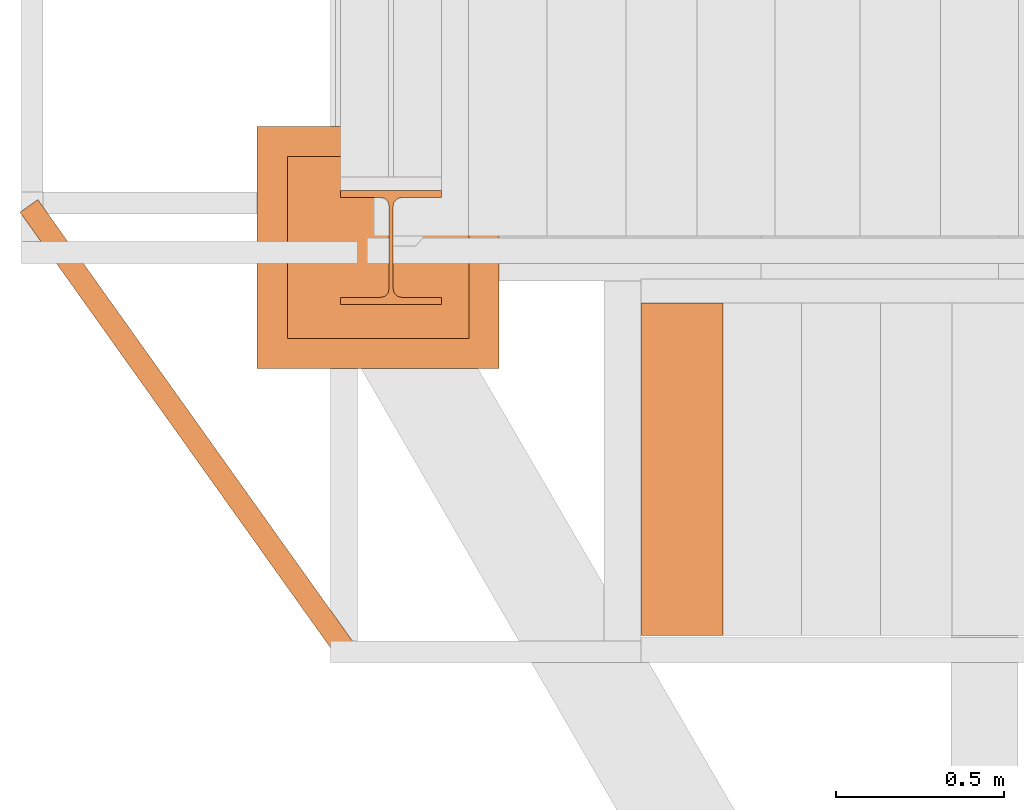
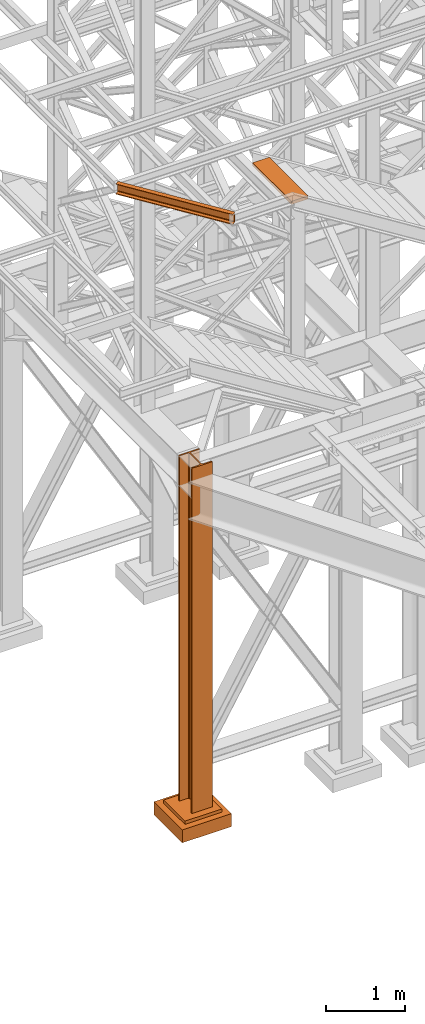
# One storey, part 18 of 208: 4 proxies.
"""IFC2X3 building model written with IfcOpenShell, lengths in millimetres."""

from ifc_helpers import new_model, entity, si_unit, converted_unit, frame, origin, origin_with_axes, place, context, subcontext, project, spatial, faceted_brep, material, element, save


model = new_model("IFC2X3")

# Units and contexts
model_context = context("Model", 3, precision=1e-05, world=origin())
plan_context = context("Plan", 3, precision=1e-05, world=origin())
body_context = subcontext(model_context, "Body", "Model", "MODEL_VIEW")
ifc_project = project(units=[si_unit("LENGTHUNIT", "METRE", prefix="MILLI"), converted_unit("PLANEANGLEUNIT", "DEGREE", entity("IfcPlaneAngleMeasure", 0.0174532925199433), si_unit("PLANEANGLEUNIT", "RADIAN"), dimensions=[0, 0, 0, 0, 0, 0, 0]), si_unit("AREAUNIT", "SQUARE_METRE"), si_unit("VOLUMEUNIT", "CUBIC_METRE")], contexts=[model_context, plan_context])

# Building, storey
building_placement = place(None, origin())
building = spatial("IfcBuilding", under=ifc_project, at=building_placement, CompositionType="COMPLEX")
storey_placement = place(building_placement, origin_with_axes())
storey = spatial("IfcBuildingStorey", under=building, at=storey_placement, Name="Geschoss", CompositionType="ELEMENT")

# Proxies
ifc_material = material(Name="35/80cm")
proxy_1_placement = place(storey_placement, frame((-3456.745037431798, -17432.57439531565, -65.01000000000022), z_axis=(0.0, 0.0, 1.0), x_axis=(1.0, 0.0, 0.0)))
element("IfcBuildingElementProxy", 1, at=proxy_1_placement, inside=storey, material=ifc_material, context=body_context, shape_type="Brep", body=[
    faceted_brep([(300.0100119209292, 0.00999999999839929, 0.01000000000027512), (300.0100119209292, 21.51000631809075, 0.01000000000027512), (183.0100057816508, 21.51000631809075, 0.01000000000027512), (169.036290997863, 24.30682016372521, 0.01000000000027512), (158.8068282401564, 34.5362885093673, 0.01000000000027512), (156.0100060126188, 48.51000143050987, 0.01000000000027512), (156.0100060126188, 291.509994695185, 0.01000000000027512), (158.8068282401564, 305.4837150669082, 0.01000000000027512), (169.036290997863, 315.7131685113891, 0.01000000000027512), (183.0100057816508, 318.5099972581847, 0.01000000000027512), (300.0100119209292, 318.5099972581847, 0.01000000000027512), (300.0100119209292, 340.0100035762771, 0.01000000000027512), (0.01000000000021828, 340.0100035762771, 0.01000000000027512), (0.01000000000021828, 318.5099972581847, 0.01000000000027512), (117.0100061392786, 318.5099972581847, 0.01000000000027512), (130.9837209230664, 315.7131685113891, 0.01000000000027512), (141.213183680773, 305.4837150669082, 0.01000000000027512), (144.0100059083106, 291.509994695185, 0.01000000000027512), (144.0100059083106, 48.51000143050987, 0.01000000000027512), (141.213183680773, 34.5362885093673, 0.01000000000027512), (130.9837209230664, 24.30682016372521, 0.01000000000027512), (117.0100061392786, 21.51000631809075, 0.01000000000027512), (0.01000000000021828, 21.51000631809075, 0.01000000000027512), (0.01000000000021828, 0.00999999999839929, 0.01000000000027512), (300.0100119209292, 21.51000631809075, 5350.010005364416), (300.0100119209292, 0.00999999999839929, 5350.010005364416), (0.01000000000021828, 0.00999999999839929, 5350.010005364416), (0.01000000000021828, 21.51000631809075, 5350.010005364416), (117.0100061392786, 21.51000631809075, 5350.010005364416), (130.9837209230664, 24.30682016372521, 5350.010005364416), (141.213183680773, 34.5362885093673, 5350.010005364416), (144.0100059083106, 48.51000143050987, 5350.010005364416), (144.0100059083106, 291.509994695185, 5350.010005364416), (141.213183680773, 305.4837150669082, 5350.010005364416), (130.9837209230664, 315.7131685113891, 5350.010005364416), (117.0100061392786, 318.5099972581847, 5350.010005364416), (0.01000000000021828, 318.5099972581847, 5350.010005364416), (0.01000000000021828, 340.0100035762771, 5350.010005364416), (300.0100119209292, 340.0100035762771, 5350.010005364416), (300.0100119209292, 318.5099972581847, 5350.010005364416), (183.0100057816508, 318.5099972581847, 5350.010005364416), (169.036290997863, 315.7131685113891, 5350.010005364416), (158.8068282401564, 305.4837150669082, 5350.010005364416), (156.0100060126188, 291.509994695185, 5350.010005364416), (156.0100060126188, 48.51000143050987, 5350.010005364416), (158.8068282401564, 34.5362885093673, 5350.010005364416), (169.036290997863, 24.30682016372521, 5350.010005364416), (183.0100057816508, 21.51000631809075, 5350.010005364416), (300.0100119209292, 21.51000631809075, 0.01000000000027512), (300.0100119209292, 0.00999999999839929, 0.01000000000027512), (300.0100119209292, 0.00999999999839929, 5350.010005364416), (300.0100119209292, 21.51000631809075, 5350.010005364416), (183.0100057816508, 21.51000631809075, 0.01000000000027512), (300.0100119209292, 21.51000631809075, 0.01000000000027512), (300.0100119209292, 21.51000631809075, 5350.010005364416), (183.0100057816508, 21.51000631809075, 5350.010005364416), (169.036290997863, 24.30682016372521, 0.01000000000027512), (183.0100057816508, 21.51000631809075, 0.01000000000027512), (183.0100057816508, 21.51000631809075, 5350.010005364416), (169.036290997863, 24.30682016372521, 5350.010005364416), (158.8068282401564, 34.5362885093673, 0.01000000000027512), (169.036290997863, 24.30682016372521, 0.01000000000027512), (169.036290997863, 24.30682016372521, 5350.010005364416), (158.8068282401564, 34.5362885093673, 5350.010005364416), (156.0100060126188, 48.51000143050987, 0.01000000000027512), (158.8068282401564, 34.5362885093673, 0.01000000000027512), (158.8068282401564, 34.5362885093673, 5350.010005364416), (156.0100060126188, 48.51000143050987, 5350.010005364416), (156.0100060126188, 291.509994695185, 0.01000000000027512), (156.0100060126188, 48.51000143050987, 0.01000000000027512), (156.0100060126188, 48.51000143050987, 5350.010005364416), (156.0100060126188, 291.509994695185, 5350.010005364416), (158.8068282401564, 305.4837150669082, 0.01000000000027512), (156.0100060126188, 291.509994695185, 0.01000000000027512), (156.0100060126188, 291.509994695185, 5350.010005364416), (158.8068282401564, 305.4837150669082, 5350.010005364416), (169.036290997863, 315.7131685113891, 0.01000000000027512), (158.8068282401564, 305.4837150669082, 0.01000000000027512), (158.8068282401564, 305.4837150669082, 5350.010005364416), (169.036290997863, 315.7131685113891, 5350.010005364416), (183.0100057816508, 318.5099972581847, 0.01000000000027512), (169.036290997863, 315.7131685113891, 0.01000000000027512), (169.036290997863, 315.7131685113891, 5350.010005364416), (183.0100057816508, 318.5099972581847, 5350.010005364416), (300.0100119209292, 318.5099972581847, 0.01000000000027512), (183.0100057816508, 318.5099972581847, 0.01000000000027512), (183.0100057816508, 318.5099972581847, 5350.010005364416), (300.0100119209292, 318.5099972581847, 5350.010005364416), (300.0100119209292, 340.0100035762771, 0.01000000000027512), (300.0100119209292, 318.5099972581847, 0.01000000000027512), (300.0100119209292, 318.5099972581847, 5350.010005364416), (300.0100119209292, 340.0100035762771, 5350.010005364416), (0.01000000000021828, 340.0100035762771, 0.01000000000027512), (300.0100119209292, 340.0100035762771, 0.01000000000027512), (300.0100119209292, 340.0100035762771, 5350.010005364416), (0.01000000000021828, 340.0100035762771, 5350.010005364416), (0.01000000000021828, 318.5099972581847, 0.01000000000027512), (0.01000000000021828, 340.0100035762771, 0.01000000000027512), (0.01000000000021828, 340.0100035762771, 5350.010005364416), (0.01000000000021828, 318.5099972581847, 5350.010005364416), (117.0100061392786, 318.5099972581847, 0.01000000000027512), (0.01000000000021828, 318.5099972581847, 0.01000000000027512), (0.01000000000021828, 318.5099972581847, 5350.010005364416), (117.0100061392786, 318.5099972581847, 5350.010005364416), (130.9837209230664, 315.7131685113891, 0.01000000000027512), (117.0100061392786, 318.5099972581847, 0.01000000000027512), (117.0100061392786, 318.5099972581847, 5350.010005364416), (130.9837209230664, 315.7131685113891, 5350.010005364416), (141.213183680773, 305.4837150669082, 0.01000000000027512), (130.9837209230664, 315.7131685113891, 0.01000000000027512), (130.9837209230664, 315.7131685113891, 5350.010005364416), (141.213183680773, 305.4837150669082, 5350.010005364416), (144.0100059083106, 291.509994695185, 0.01000000000027512), (141.213183680773, 305.4837150669082, 0.01000000000027512), (141.213183680773, 305.4837150669082, 5350.010005364416), (144.0100059083106, 291.509994695185, 5350.010005364416), (144.0100059083106, 48.51000143050987, 0.01000000000027512), (144.0100059083106, 291.509994695185, 0.01000000000027512), (144.0100059083106, 291.509994695185, 5350.010005364416), (144.0100059083106, 48.51000143050987, 5350.010005364416), (141.213183680773, 34.5362885093673, 0.01000000000027512), (144.0100059083106, 48.51000143050987, 0.01000000000027512), (144.0100059083106, 48.51000143050987, 5350.010005364416), (141.213183680773, 34.5362885093673, 5350.010005364416), (130.9837209230664, 24.30682016372521, 0.01000000000027512), (141.213183680773, 34.5362885093673, 0.01000000000027512), (141.213183680773, 34.5362885093673, 5350.010005364416), (130.9837209230664, 24.30682016372521, 5350.010005364416), (117.0100061392786, 21.51000631809075, 0.01000000000027512), (130.9837209230664, 24.30682016372521, 0.01000000000027512), (130.9837209230664, 24.30682016372521, 5350.010005364416), (117.0100061392786, 21.51000631809075, 5350.010005364416), (0.01000000000021828, 21.51000631809075, 0.01000000000027512), (117.0100061392786, 21.51000631809075, 0.01000000000027512), (117.0100061392786, 21.51000631809075, 5350.010005364416), (0.01000000000021828, 21.51000631809075, 5350.010005364416), (0.01000000000021828, 0.00999999999839929, 0.01000000000027512), (0.01000000000021828, 21.51000631809075, 0.01000000000027512), (0.01000000000021828, 21.51000631809075, 5350.010005364416), (0.01000000000021828, 0.00999999999839929, 5350.010005364416), (300.0100119209292, 0.00999999999839929, 0.01000000000027512), (0.01000000000021828, 0.00999999999839929, 0.01000000000027512), (0.01000000000021828, 0.00999999999839929, 5350.010005364416), (300.0100119209292, 0.00999999999839929, 5350.010005364416)], [[[0, 1, 2, 3, 4, 5, 6, 7, 8, 9, 10, 11, 12, 13, 14, 15, 16, 17, 18, 19, 20, 21, 22, 23]], [[24, 25, 26, 27, 28, 29, 30, 31, 32, 33, 34, 35, 36, 37, 38, 39, 40, 41, 42, 43, 44, 45, 46, 47]], [[48, 49, 50, 51]], [[52, 53, 54, 55]], [[56, 57, 58, 59]], [[60, 61, 62, 63]], [[64, 65, 66, 67]], [[68, 69, 70, 71]], [[72, 73, 74, 75]], [[76, 77, 78, 79]], [[80, 81, 82, 83]], [[84, 85, 86, 87]], [[88, 89, 90, 91]], [[92, 93, 94, 95]], [[96, 97, 98, 99]], [[100, 101, 102, 103]], [[104, 105, 106, 107]], [[108, 109, 110, 111]], [[112, 113, 114, 115]], [[116, 117, 118, 119]], [[120, 121, 122, 123]], [[124, 125, 126, 127]], [[128, 129, 130, 131]], [[132, 133, 134, 135]], [[136, 137, 138, 139]], [[140, 141, 142, 143]]], orient=[[False], [False], [False], [False], [False], [False], [False], [False], [False], [False], [False], [False], [False], [False], [False], [False], [False], [False], [False], [False], [False], [False], [False], [False], [False], [False]]),
])
proxy_2_placement = place(storey_placement, frame((-3705.215590090974, -17622.57439531565, -315.01), z_axis=(0.0, 0.0, 1.0), x_axis=(1.0, 0.0, 0.0)))
element("IfcBuildingElementProxy", 2, at=proxy_2_placement, inside=storey, context=body_context, shape_type="Brep", body=[
    faceted_brep([(630.0100000000002, 630.0099999999984, 250.01), (630.0100000000002, 90.0099999999984, 250.01), (90.01000000000022, 90.0099999999984, 250.01), (90.01000000000022, 630.0099999999984, 250.01), (630.0100000000002, 630.0099999999984, 200.01), (630.0100000000002, 90.0099999999984, 200.01), (630.0100000000002, 90.0099999999984, 250.01), (630.0100000000002, 630.0099999999984, 250.01), (90.01000000000022, 630.0099999999984, 200.01), (630.0100000000002, 630.0099999999984, 200.01), (630.0100000000002, 630.0099999999984, 250.01), (90.01000000000022, 630.0099999999984, 250.01), (90.01000000000022, 90.0099999999984, 200.01), (90.01000000000022, 630.0099999999984, 200.01), (90.01000000000022, 630.0099999999984, 250.01), (90.01000000000022, 90.0099999999984, 250.01), (630.0100000000002, 90.0099999999984, 200.01), (90.01000000000022, 90.0099999999984, 200.01), (90.01000000000022, 90.0099999999984, 250.01), (630.0100000000002, 90.0099999999984, 250.01), (720.0100000000002, 0.00999999999839929, 0.009999999999990905), (720.0100000000002, 720.0099999999984, 0.009999999999990905), (0.01000000000021828, 720.0099999999984, 0.009999999999990905), (0.01000000000021828, 0.00999999999839929, 0.009999999999990905), (720.0100000000002, 720.0099999999984, 200.01), (720.0100000000002, 0.00999999999839929, 200.01), (0.01000000000021828, 0.00999999999839929, 200.01), (0.01000000000021828, 720.0099999999984, 200.01), (90.01000000000022, 90.0099999999984, 200.01), (630.0100000000002, 90.0099999999984, 200.01), (630.0100000000002, 630.0099999999984, 200.01), (90.01000000000022, 630.0099999999984, 200.01), (720.0100000000002, 720.0099999999984, 0.009999999999990905), (720.0100000000002, 0.00999999999839929, 0.009999999999990905), (720.0100000000002, 0.00999999999839929, 200.01), (720.0100000000002, 720.0099999999984, 200.01), (0.01000000000021828, 720.0099999999984, 0.009999999999990905), (720.0100000000002, 720.0099999999984, 0.009999999999990905), (720.0100000000002, 720.0099999999984, 200.01), (0.01000000000021828, 720.0099999999984, 200.01), (0.01000000000021828, 0.00999999999839929, 0.009999999999990905), (0.01000000000021828, 720.0099999999984, 0.009999999999990905), (0.01000000000021828, 720.0099999999984, 200.01), (0.01000000000021828, 0.00999999999839929, 200.01), (720.0100000000002, 0.00999999999839929, 0.009999999999990905), (0.01000000000021828, 0.00999999999839929, 0.009999999999990905), (0.01000000000021828, 0.00999999999839929, 200.01), (720.0100000000002, 0.00999999999839929, 200.01)], [[[0, 1, 2, 3]], [[4, 5, 6, 7]], [[8, 9, 10, 11]], [[12, 13, 14, 15]], [[16, 17, 18, 19]], [[20, 21, 22, 23]], [[24, 25, 26, 27], [28, 29, 30, 31]], [[32, 33, 34, 35]], [[36, 37, 38, 39]], [[40, 41, 42, 43]], [[44, 45, 46, 47]]], orient=[[False], [False], [False], [False], [False], [False], [False, False], [False], [False], [False], [False]]),
])
proxy_3_placement = place(storey_placement, frame((-2563.970189809399, -18416.66561009758, 9656.79258468832), z_axis=(0.0, 0.0, 1.0), x_axis=(1.0, 0.0, 0.0)))
element("IfcBuildingElementProxy", 3, at=proxy_3_placement, inside=storey, context=body_context, shape_type="Brep", body=[
    faceted_brep([(0.01000000000021828, 0.00999999999839929, 0.01000000000021828), (244.0584869528593, 0.00999999999839929, 0.01000000000021828), (244.0584869528593, 988.9080206708568, 0.01000000000021828), (0.01000000000021828, 988.9080206708568, 0.01000000000021828), (244.0584869528593, 0.00999999999839929, 50.01000000000022), (0.01000000000021828, 0.00999999999839929, 50.01000000000022), (0.01000000000021828, 988.9080206708568, 50.01000000000022), (244.0584869528593, 988.9080206708568, 50.01000000000022), (244.0584869528593, 0.00999999999839929, 0.01000000000021828), (0.01000000000021828, 0.00999999999839929, 0.01000000000021828), (0.01000000000021828, 0.00999999999839929, 50.01000000000022), (244.0584869528593, 0.00999999999839929, 50.01000000000022), (244.0584869528593, 988.9080206708568, 0.01000000000021828), (244.0584869528593, 0.00999999999839929, 0.01000000000021828), (244.0584869528593, 0.00999999999839929, 50.01000000000022), (244.0584869528593, 988.9080206708568, 50.01000000000022), (0.01000000000021828, 988.9080206708568, 0.01000000000021828), (244.0584869528593, 988.9080206708568, 0.01000000000021828), (244.0584869528593, 988.9080206708568, 50.01000000000022), (0.01000000000021828, 988.9080206708568, 50.01000000000022), (0.01000000000021828, 0.00999999999839929, 0.01000000000021828), (0.01000000000021828, 988.9080206708568, 0.01000000000021828), (0.01000000000021828, 988.9080206708568, 50.01000000000022), (0.01000000000021828, 0.00999999999839929, 50.01000000000022)], [[[0, 1, 2, 3]], [[4, 5, 6, 7]], [[8, 9, 10, 11]], [[12, 13, 14, 15]], [[16, 17, 18, 19]], [[20, 21, 22, 23]]], orient=[[False], [False], [False], [False], [False], [False]]),
])
proxy_4_placement = place(storey_placement, frame((-4410.879027112589, -18486.68590254766, 9699.99), z_axis=(0.0, 0.0, 1.0), x_axis=(1.0, 0.0, 0.0)))
element("IfcBuildingElementProxy", 4, at=proxy_4_placement, inside=storey, context=body_context, shape_type="Brep", body=[
    faceted_brep([(0.01000000000021828, 1329.089691492183, 0.01000000000021828), (0.01000000000021828, 1329.089691492183, 3.132428070246533), (947.4429470007635, 0.00999999999839929, 3.132428070246533), (947.4429470007635, 0.00999999999839929, 0.01000000000021828), (0.01000000000021828, 1329.089691492183, 3.132428070246533), (0.2076575136252359, 1329.230590580919, 4.748288908171162), (947.6406045143849, 0.1508990887305117, 4.748288908171162), (947.4429470007635, 0.00999999999839929, 3.132428070246533), (0.2076575136252359, 1329.230590580919, 4.748288908171162), (0.7831402898955275, 1329.640820363085, 6.221534443444398), (948.2160872906552, 0.5611288709005748, 6.221534443444398), (947.6406045143849, 0.1508990887305117, 4.748288908171162), (0.7831402898955275, 1329.640820363085, 6.221534443444398), (1.685681495109748, 1330.284191976069, 7.422126703873801), (949.1186284958712, 1.204500483883749, 7.422126703873801), (948.2160872906552, 0.5611288709005748, 6.221534443444398), (1.685681495109748, 1330.284191976069, 7.422126703873801), (2.835615306352338, 1331.103916069209, 8.244091391710754), (950.2685623071156, 2.024224577024143, 8.244091391710754), (949.1186284958712, 1.204500483883749, 7.422126703873801), (2.835615306352338, 1331.103916069209, 8.244091391710754), (4.13143898378803, 1332.027636963809, 8.614912102195376), (951.5643859845441, 2.947945471623825, 8.614912102195376), (950.2685623071156, 2.024224577024143, 8.244091391710754), (4.13143898378803, 1332.027636963809, 8.614912102195376), (38.9633658059156, 1356.857387465407, 12.0369859867169), (986.3963128066753, 27.77769597322549, 12.0369859867169), (951.5643859845441, 2.947945471623825, 8.614912102195376), (38.9633658059156, 1356.857387465407, 12.0369859867169), (41.43721100828407, 1358.620854627825, 12.74491643400506), (988.8701580090474, 29.54116313564009, 12.74491643400506), (986.3963128066753, 27.77769597322549, 12.0369859867169), (41.43721100828407, 1358.620854627825, 12.74491643400506), (43.63253919338968, 1360.185782442, 14.31412174714933), (991.0654861941493, 31.10609094981555, 14.31412174714933), (988.8701580090474, 29.54116313564009, 12.74491643400506), (43.63253919338968, 1360.185782442, 14.31412174714933), (45.35557240334674, 1361.414037339513, 16.60616151705835), (992.7885194041028, 32.33434584732822, 16.60616151705835), (991.0654861941493, 31.10609094981555, 14.31412174714933), (45.35557240334674, 1361.414037339513, 16.60616151705835), (46.45422133986176, 1362.197203287291, 19.41872117530875), (993.8871683406196, 33.11751179510611, 19.41872117530875), (992.7885194041028, 32.33434584732822, 16.60616151705835), (46.45422133986176, 1362.197203287291, 19.41872117530875), (46.83156750223498, 1362.46619245669, 22.50354641134618), (994.2645145029946, 33.3865009645051, 22.50354641134618), (993.8871683406196, 33.11751179510611, 19.41872117530875), (46.83156750223498, 1362.46619245669, 22.50354641134618), (46.83156750223498, 1362.46619245669, 137.5164535886524), (994.2645145029946, 33.3865009645051, 137.5164535886524), (994.2645145029946, 33.3865009645051, 22.50354641134618), (46.83156750223498, 1362.46619245669, 137.5164535886524), (46.45422133986176, 1362.197203287291, 140.6012788246917), (993.8871683406196, 33.11751179510611, 140.6012788246917), (994.2645145029946, 33.3865009645051, 137.5164535886524), (46.45422133986176, 1362.197203287291, 140.6012788246917), (45.35557240334674, 1361.414037339513, 143.4138384829403), (992.7885194041028, 32.33434584732822, 143.4138384829403), (993.8871683406196, 33.11751179510611, 140.6012788246917), (45.35557240334674, 1361.414037339513, 143.4138384829403), (43.63253919338968, 1360.185782442, 145.7058782528493), (991.0654861941493, 31.10609094981555, 145.7058782528493), (992.7885194041028, 32.33434584732822, 143.4138384829403), (43.63253919338968, 1360.185782442, 145.7058782528493), (41.43721100828407, 1358.620854627825, 147.2750835659936), (988.8701580090474, 29.54116313564009, 147.2750835659936), (991.0654861941493, 31.10609094981555, 145.7058782528493), (41.43721100828407, 1358.620854627825, 147.2750835659936), (38.9633658059156, 1356.857387465407, 147.9830140132817), (986.3963128066753, 27.77769597322549, 147.9830140132817), (988.8701580090474, 29.54116313564009, 147.2750835659936), (38.9633658059156, 1356.857387465407, 147.9830140132817), (4.13143898378803, 1332.027636963809, 151.4050878978032), (951.5643859845441, 2.947945471623825, 151.4050878978032), (986.3963128066753, 27.77769597322549, 147.9830140132817), (4.13143898378803, 1332.027636963809, 151.4050878978032), (2.835615306352338, 1331.103916069209, 151.7759086082879), (950.2685623071156, 2.024224577024143, 151.7759086082879), (951.5643859845441, 2.947945471623825, 151.4050878978032), (2.835615306352338, 1331.103916069209, 151.7759086082879), (1.685681495109748, 1330.284191976069, 152.5978732961248), (949.1186284958712, 1.204500483883749, 152.5978732961248), (950.2685623071156, 2.024224577024143, 151.7759086082879), (1.685681495109748, 1330.284191976069, 152.5978732961248), (0.7831402898955275, 1329.640820363085, 153.7984655565542), (948.2160872906552, 0.5611288709005748, 153.7984655565542), (949.1186284958712, 1.204500483883749, 152.5978732961248), (0.7831402898955275, 1329.640820363085, 153.7984655565542), (0.2076575136252359, 1329.230590580919, 155.2717110918275), (947.6406045143849, 0.1508990887305117, 155.2717110918275), (948.2160872906552, 0.5611288709005748, 153.7984655565542), (0.2076575136252359, 1329.230590580919, 155.2717110918275), (0.01000000000021828, 1329.089691492183, 156.8875719297521), (947.4429470007635, 0.00999999999839929, 156.8875719297521), (947.6406045143849, 0.1508990887305117, 155.2717110918275), (0.01000000000021828, 1329.089691492183, 156.8875719297521), (0.01000000000021828, 1329.089691492183, 160.0100000000002), (947.4429470007635, 0.00999999999839929, 160.0100000000002), (947.4429470007635, 0.00999999999839929, 156.8875719297521), (0.01000000000021828, 1329.089691492183, 160.0100000000002), (52.93872848078718, 1366.819649104236, 160.0100000000002), (1000.371675481547, 37.73995761205151, 160.0100000000002), (947.4429470007635, 0.00999999999839929, 160.0100000000002), (52.93872848078718, 1366.819649104236, 160.0100000000002), (52.93872848078718, 1366.819649104236, 0.01000000000021828), (1000.371675481547, 37.73995761205151, 0.01000000000021828), (1000.371675481547, 37.73995761205151, 160.0100000000002), (52.93872848078718, 1366.819649104236, 0.01000000000021828), (0.01000000000021828, 1329.089691492183, 0.01000000000021828), (947.4429470007635, 0.00999999999839929, 0.01000000000021828), (1000.371675481547, 37.73995761205151, 0.01000000000021828), (0.01000000000021828, 1329.089691492183, 0.01000000000021828), (52.93872848078718, 1366.819649104236, 0.01000000000021828), (52.93872848078718, 1366.819649104236, 160.0100000000002), (0.01000000000021828, 1329.089691492183, 160.0100000000002), (0.01000000000021828, 1329.089691492183, 156.8875719297521), (0.2076575136252359, 1329.230590580919, 155.2717110918275), (0.7831402898955275, 1329.640820363085, 153.7984655565542), (1.685681495109748, 1330.284191976069, 152.5978732961248), (2.835615306352338, 1331.103916069209, 151.7759086082879), (4.13143898378803, 1332.027636963809, 151.4050878978032), (38.9633658059156, 1356.857387465407, 147.9830140132817), (41.43721100828407, 1358.620854627825, 147.2750835659936), (43.63253919338968, 1360.185782442, 145.7058782528493), (45.35557240334674, 1361.414037339513, 143.4138384829403), (46.45422133986176, 1362.197203287291, 140.6012788246917), (46.83156750223498, 1362.46619245669, 137.5164535886524), (46.83156750223498, 1362.46619245669, 22.50354641134618), (46.45422133986176, 1362.197203287291, 19.41872117530875), (45.35557240334674, 1361.414037339513, 16.60616151705835), (43.63253919338968, 1360.185782442, 14.31412174714933), (41.43721100828407, 1358.620854627825, 12.74491643400506), (38.9633658059156, 1356.857387465407, 12.0369859867169), (4.13143898378803, 1332.027636963809, 8.614912102195376), (2.835615306352338, 1331.103916069209, 8.244091391710754), (1.685681495109748, 1330.284191976069, 7.422126703873801), (0.7831402898955275, 1329.640820363085, 6.221534443444398), (0.2076575136252359, 1329.230590580919, 4.748288908171162), (0.01000000000021828, 1329.089691492183, 3.132428070246533), (947.4429470007635, 0.00999999999839929, 0.01000000000021828), (947.4429470007635, 0.00999999999839929, 3.132428070246533), (947.6406045143849, 0.1508990887305117, 4.748288908171162), (948.2160872906552, 0.5611288709005748, 6.221534443444398), (949.1186284958712, 1.204500483883749, 7.422126703873801), (950.2685623071156, 2.024224577024143, 8.244091391710754), (951.5643859845441, 2.947945471623825, 8.614912102195376), (986.3963128066753, 27.77769597322549, 12.0369859867169), (988.8701580090474, 29.54116313564009, 12.74491643400506), (991.0654861941493, 31.10609094981555, 14.31412174714933), (992.7885194041028, 32.33434584732822, 16.60616151705835), (993.8871683406196, 33.11751179510611, 19.41872117530875), (994.2645145029946, 33.3865009645051, 22.50354641134618), (994.2645145029946, 33.3865009645051, 137.5164535886524), (993.8871683406196, 33.11751179510611, 140.6012788246917), (992.7885194041028, 32.33434584732822, 143.4138384829403), (991.0654861941493, 31.10609094981555, 145.7058782528493), (988.8701580090474, 29.54116313564009, 147.2750835659936), (986.3963128066753, 27.77769597322549, 147.9830140132817), (951.5643859845441, 2.947945471623825, 151.4050878978032), (950.2685623071156, 2.024224577024143, 151.7759086082879), (949.1186284958712, 1.204500483883749, 152.5978732961248), (948.2160872906552, 0.5611288709005748, 153.7984655565542), (947.6406045143849, 0.1508990887305117, 155.2717110918275), (947.4429470007635, 0.00999999999839929, 156.8875719297521), (947.4429470007635, 0.00999999999839929, 160.0100000000002), (1000.371675481547, 37.73995761205151, 160.0100000000002), (1000.371675481547, 37.73995761205151, 0.01000000000021828)], [[[0, 1, 2, 3]], [[4, 5, 6, 7]], [[8, 9, 10, 11]], [[12, 13, 14, 15]], [[16, 17, 18, 19]], [[20, 21, 22, 23]], [[24, 25, 26, 27]], [[28, 29, 30, 31]], [[32, 33, 34, 35]], [[36, 37, 38, 39]], [[40, 41, 42, 43]], [[44, 45, 46, 47]], [[48, 49, 50, 51]], [[52, 53, 54, 55]], [[56, 57, 58, 59]], [[60, 61, 62, 63]], [[64, 65, 66, 67]], [[68, 69, 70, 71]], [[72, 73, 74, 75]], [[76, 77, 78, 79]], [[80, 81, 82, 83]], [[84, 85, 86, 87]], [[88, 89, 90, 91]], [[92, 93, 94, 95]], [[96, 97, 98, 99]], [[100, 101, 102, 103]], [[104, 105, 106, 107]], [[108, 109, 110, 111]], [[112, 113, 114, 115, 116, 117, 118, 119, 120, 121, 122, 123, 124, 125, 126, 127, 128, 129, 130, 131, 132, 133, 134, 135, 136, 137, 138, 139]], [[140, 141, 142, 143, 144, 145, 146, 147, 148, 149, 150, 151, 152, 153, 154, 155, 156, 157, 158, 159, 160, 161, 162, 163, 164, 165, 166, 167]]], orient=[[False], [False], [False], [False], [False], [False], [False], [False], [False], [False], [False], [False], [False], [False], [False], [False], [False], [False], [False], [False], [False], [False], [False], [False], [False], [False], [False], [False], [False], [False]]),
])

save(model, "model.ifc")
